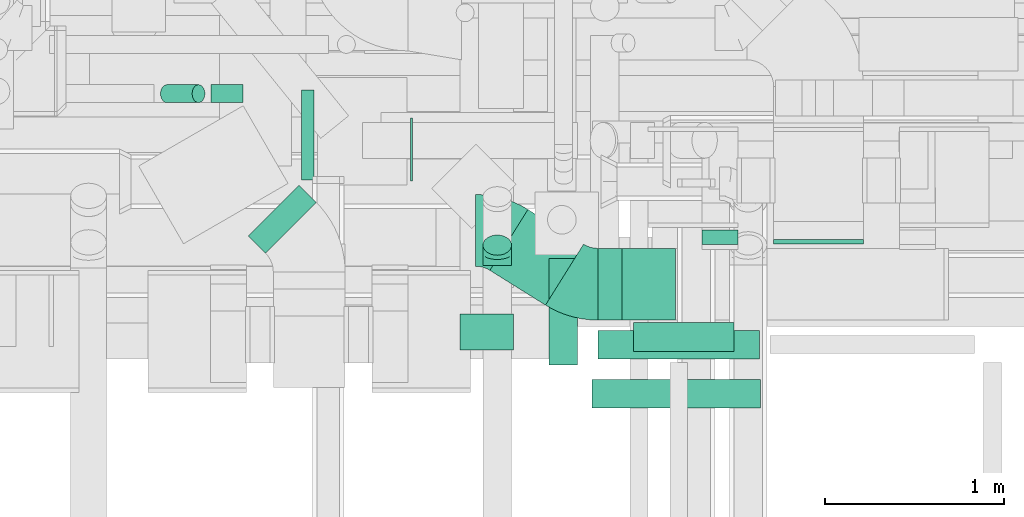
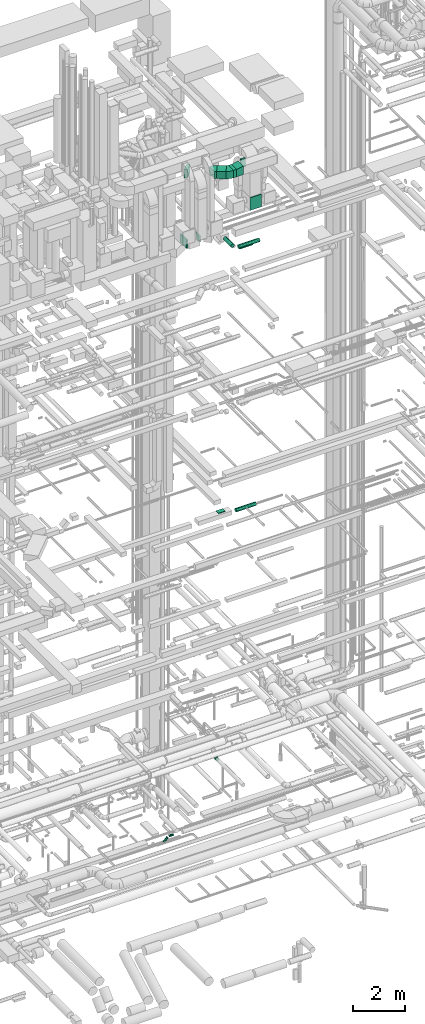
# One storey, part 231 of 337: 13 flow segments, 5 flow fittings.
"""IFC2X3 building model written with IfcOpenShell, lengths in millimetres."""

from ifc_helpers import new_model, entity, si_unit, converted_unit, derived_unit, direction, frame, frame_2d, origin, origin_2d_with_axis, place, context, subcontext, project, spatial, polyline, circle_curve, parameter, trimmed, segment, composite_curve, rectangle, circle, outline, extrude, faceted_brep, source, transform, mapped, material, type_object, type_shapes, element, save


model = new_model("IFC2X3")

# Units and contexts
model_context = context("Model", 3, precision=0.01, world=origin(), true_north=direction((6.12303176911189e-17, 1.0)))
body_context = subcontext(model_context, "Body", "Model", "MODEL_VIEW")
ifc_project = project(units=[si_unit("LENGTHUNIT", "METRE", prefix="MILLI"), si_unit("AREAUNIT", "SQUARE_METRE"), si_unit("VOLUMEUNIT", "CUBIC_METRE"), converted_unit("PLANEANGLEUNIT", "DEGREE", entity("IfcRatioMeasure", 0.0174532925199433), si_unit("PLANEANGLEUNIT", "RADIAN"), dimensions=[0, 0, 0, 0, 0, 0, 0]), si_unit("MASSUNIT", "GRAM", prefix="KILO"), derived_unit("MASSDENSITYUNIT", [(si_unit("MASSUNIT", "GRAM", prefix="KILO"), 1), (si_unit("LENGTHUNIT", "METRE"), -3)]), derived_unit("MOMENTOFINERTIAUNIT", [(si_unit("LENGTHUNIT", "METRE"), 4)]), si_unit("TIMEUNIT", "SECOND"), si_unit("FREQUENCYUNIT", "HERTZ"), si_unit("THERMODYNAMICTEMPERATUREUNIT", "DEGREE_CELSIUS"), derived_unit("THERMALTRANSMITTANCEUNIT", [(si_unit("MASSUNIT", "GRAM", prefix="KILO"), 1), (si_unit("THERMODYNAMICTEMPERATUREUNIT", "KELVIN"), -1), (si_unit("TIMEUNIT", "SECOND"), -3)]), derived_unit("VOLUMETRICFLOWRATEUNIT", [(si_unit("LENGTHUNIT", "METRE"), 3), (si_unit("TIMEUNIT", "SECOND"), -1)]), derived_unit("MASSFLOWRATEUNIT", [(si_unit("MASSUNIT", "GRAM", prefix="KILO"), 1), (si_unit("TIMEUNIT", "SECOND"), -1)]), derived_unit("ROTATIONALFREQUENCYUNIT", [(si_unit("TIMEUNIT", "SECOND"), -1)]), si_unit("ELECTRICCURRENTUNIT", "AMPERE"), si_unit("ELECTRICVOLTAGEUNIT", "VOLT"), si_unit("POWERUNIT", "WATT"), si_unit("FORCEUNIT", "NEWTON", prefix="KILO"), si_unit("ILLUMINANCEUNIT", "LUX"), si_unit("LUMINOUSFLUXUNIT", "LUMEN"), si_unit("LUMINOUSINTENSITYUNIT", "CANDELA"), derived_unit("USERDEFINED", [(si_unit("MASSUNIT", "GRAM", prefix="KILO"), -1), (si_unit("LENGTHUNIT", "METRE"), -2), (si_unit("TIMEUNIT", "SECOND"), 3), (si_unit("LUMINOUSFLUXUNIT", "LUMEN"), 1)]), derived_unit("LINEARVELOCITYUNIT", [(si_unit("LENGTHUNIT", "METRE"), 1), (si_unit("TIMEUNIT", "SECOND"), -1)]), si_unit("PRESSUREUNIT", "PASCAL"), derived_unit("USERDEFINED", [(si_unit("LENGTHUNIT", "METRE"), -2), (si_unit("MASSUNIT", "GRAM", prefix="KILO"), 1), (si_unit("TIMEUNIT", "SECOND"), -2)]), derived_unit("LINEARFORCEUNIT", [(si_unit("MASSUNIT", "GRAM", prefix="KILO"), 1), (si_unit("LENGTHUNIT", "METRE"), 1), (si_unit("TIMEUNIT", "SECOND"), -2), (si_unit("LENGTHUNIT", "METRE"), -1)]), derived_unit("PLANARFORCEUNIT", [(si_unit("MASSUNIT", "GRAM", prefix="KILO"), 1), (si_unit("LENGTHUNIT", "METRE"), 1), (si_unit("TIMEUNIT", "SECOND"), -2), (si_unit("LENGTHUNIT", "METRE"), -2)])], contexts=[model_context])

# Site, building, storey
site_placement = place(None, origin())
site = spatial("IfcSite", under=ifc_project, at=site_placement, CompositionType="ELEMENT")
building_placement = place(site_placement, origin())
building = spatial("IfcBuilding", under=site, at=building_placement, CompositionType="ELEMENT")
storey_placement = place(building_placement, origin())
storey = spatial("IfcBuildingStorey", under=building, at=storey_placement, CompositionType="ELEMENT", Elevation=0.0)

# Flow segments
duct_segment_type_1 = type_object("IfcDuctSegmentType", PredefinedType="NOTDEFINED")
flow_segment_1_placement = place(storey_placement, frame((60120.56, 8169.63, 15070.0)))
element("IfcFlowSegment", 1, at=flow_segment_1_placement, inside=storey, type_object=duct_segment_type_1, context=body_context, shape_type="SweptSolid", body=[
    extrude(rectangle(XDim=300.000000000001, YDim=200.0, at=origin_2d_with_axis()), frame((150.0, 100.0, 0.0)), (0.0, 0.0, 1.0), 30.00000000003),
])
flow_segment_2_placement = place(storey_placement, frame((61470.03, 8756.6, 30600.0)))
element("IfcFlowSegment", 2, at=flow_segment_2_placement, inside=storey, type_object=duct_segment_type_1, context=body_context, shape_type="SweptSolid", body=[
    extrude(rectangle(XDim=82.0000000000203, YDim=199.999999999998, at=origin_2d_with_axis()), frame((100.0, 41.0, 0.0), z_axis=(0.0, 0.0, 1.0), x_axis=(0.0, -1.0, 0.0)), (0.0, 0.0, 1.0), 400.000000000004),
])
flow_segment_3_placement = place(storey_placement, frame((60889.03, 8336.6, 30600.0)))
element("IfcFlowSegment", 3, at=flow_segment_3_placement, inside=storey, type_object=duct_segment_type_1, context=body_context, shape_type="SweptSolid", body=[
    extrude(rectangle(XDim=134.470658806428, YDim=400.0, at=origin_2d_with_axis()), frame((67.24, 200.0, 0.0), z_axis=(0.0, 0.0, 1.0), x_axis=(-1.0, 0.0, 0.0)), (0.0, 0.0, 1.0), 349.999999999998),
])
flow_segment_4_placement = place(storey_placement, frame((60287.7, 8420.18, 30600.0)))
element("IfcFlowSegment", 4, at=flow_segment_4_placement, inside=storey, type_object=duct_segment_type_1, context=body_context, shape_type="SweptSolid", body=[
    extrude(rectangle(XDim=365.402204408748, YDim=399.999999999998, at=origin_2d_with_axis()), frame((260.92, 266.43, 0.0), z_axis=(0.0, 0.0, 1.0), x_axis=(-0.848048096156388, 0.529919264233266, 0.0)), (0.0, 0.0, 1.0), 349.999999999998),
])
flow_segment_5_placement = place(storey_placement, frame((59237.24, 9118.57, 27350.0)))
element("IfcFlowSegment", 5, at=flow_segment_5_placement, inside=storey, type_object=duct_segment_type_1, context=body_context, shape_type="SweptSolid", body=[
    extrude(rectangle(XDim=68.403733792958, YDim=500.0, at=origin_2d_with_axis()), frame((34.2, 250.0, 0.0), z_axis=(0.0, 0.0, 1.0), x_axis=(-1.0, 0.0, 0.0)), (0.0, 0.0, 1.0), 400.000000000004),
])
flow_segment_6_placement = place(storey_placement, frame((59845.64, 9113.12, 27450.0)))
element("IfcFlowSegment", 6, at=flow_segment_6_placement, inside=storey, type_object=duct_segment_type_1, context=body_context, shape_type="SweptSolid", body=[
    extrude(rectangle(XDim=11.4684169262546, YDim=349.999999999999, at=origin_2d_with_axis()), frame((5.73, 175.0, 0.0), z_axis=(0.0, 0.0, 1.0), x_axis=(-1.0, 0.0, 0.0)), (0.0, 0.0, 1.0), 300.000000000001),
])
flow_segment_7_placement = place(storey_placement, frame((58941.48, 8710.41, 31000.0)))
element("IfcFlowSegment", 7, at=flow_segment_7_placement, inside=storey, type_object=duct_segment_type_1, context=body_context, shape_type="SweptSolid", body=[
    extrude(rectangle(XDim=134.314575050798, YDim=399.999999999999, at=origin_2d_with_axis()), frame((188.91, 188.91, 0.0), z_axis=(0.0, 0.0, 1.0), x_axis=(-0.707106781186648, 0.707106781186447, 0.0)), (0.0, 0.0, 1.0), 400.000000000004),
])
duct_segment_type_2 = type_object("IfcDuctSegmentType", PredefinedType="NOTDEFINED")
flow_segment_8_placement = place(storey_placement, frame((58733.86, 9547.39, -601.6)))
element("IfcFlowSegment", 8, at=flow_segment_8_placement, inside=storey, type_object=duct_segment_type_2, context=body_context, shape_type="SweptSolid", body=[
    extrude(circle(Radius=50.0, at=origin_2d_with_axis()), frame((0.0, 51.6, 51.6), z_axis=(1.0, 0.0, 0.0), x_axis=(0.0, -1.0, 0.0)), (0.0, 0.0, 1.0), 178.14982376268),
])
flow_segment_9_placement = place(storey_placement, frame((58449.78, 9547.39, -792.66)))
element("IfcFlowSegment", 9, at=flow_segment_9_placement, inside=storey, type_object=duct_segment_type_2, context=body_context, shape_type="SweptSolid", body=[
    extrude(circle(Radius=50.0, at=origin_2d_with_axis()), frame((36.95, 51.6, 36.95), z_axis=(0.707106781186546, 0.0, 0.707106781186549), x_axis=(0.0, 1.0, 0.0)), (0.0, 0.0, 1.0), 249.497474683054),
])
flow_segment_10_placement = place(storey_placement, frame((60890.56, 8118.04, 14868.4)))
element("IfcFlowSegment", 10, at=flow_segment_10_placement, inside=storey, type_object=duct_segment_type_2, context=body_context, shape_type="SweptSolid", body=[
    extrude(circle(Radius=80.0, at=origin_2d_with_axis()), frame((0.0, 81.6, 81.6), z_axis=(1.0, 0.0, 0.0), x_axis=(0.0, 1.0, 0.0)), (0.0, 0.0, 1.0), 900.000000000003),
])
flow_segment_11_placement = place(storey_placement, frame((60856.21, 7844.07, 27518.4)))
element("IfcFlowSegment", 11, at=flow_segment_11_placement, inside=storey, type_object=duct_segment_type_2, context=body_context, shape_type="SweptSolid", body=[
    extrude(circle(Radius=80.0, at=origin_2d_with_axis()), frame((0.0, 81.6, 81.6), z_axis=(1.0, 0.0, 0.0), x_axis=(0.0, 1.0, 0.0)), (0.0, 0.0, 1.0), 939.375000000018),
])
flow_segment_12_placement = place(storey_placement, frame((60614.62, 8085.66, 27518.4)))
element("IfcFlowSegment", 12, at=flow_segment_12_placement, inside=storey, type_object=duct_segment_type_2, context=body_context, shape_type="SweptSolid", body=[
    extrude(circle(Radius=80.0, at=origin_2d_with_axis()), frame((81.6, 0.0, 81.6), z_axis=(0.0, 1.0, 0.0), x_axis=(1.0, 0.0, 0.0)), (0.0, 0.0, 1.0), 594.360142446069),
])
flow_segment_13_placement = place(storey_placement, frame((61088.45, 8160.81, 27218.4)))
element("IfcFlowSegment", 13, at=flow_segment_13_placement, inside=storey, type_object=duct_segment_type_2, context=body_context, shape_type="SweptSolid", body=[
    extrude(circle(Radius=80.0, at=origin_2d_with_axis()), frame((0.0, 81.6, 81.6), z_axis=(1.0, 0.0, 0.0), x_axis=(0.0, -1.0, 0.0)), (0.0, 0.0, 1.0), 559.999999999959),
])

# Flow fittings
ifc_material = material()
duct_fitting_type_1 = type_object("IfcDuctFittingType", PredefinedType="NOTDEFINED", material=ifc_material)
shared_shape_1 = source(origin(), body_context, "Body", "SweptSolid", [
    extrude(rectangle(XDim=24.9999999999999, YDim=500.0, at=origin_2d_with_axis()), frame((12.5, 0.0, -300.0)), (0.0, 0.0, 1.0), 600.0),
])
type_shapes(duct_fitting_type_1, [shared_shape_1])
flow_fitting_1_placement = place(storey_placement, frame((62120.03, 8786.6, 28750.0), z_axis=(0.0, 0.0, 1.0), x_axis=(0.0, -1.0, 0.0)))
element("IfcFlowFitting", 14, at=flow_fitting_1_placement, inside=storey, type_object=duct_fitting_type_1, material=ifc_material, context=body_context, shape_type="MappedRepresentation", body=[
    mapped(shared_shape_1, transform((0.0, 0.0, 0.0), scale=1.0)),
])
duct_fitting_type_2 = type_object("IfcDuctFittingType", PredefinedType="NOTDEFINED", material=ifc_material)
shared_shape_2 = source(origin(), body_context, "Body", "SweptSolid", [
    extrude(outline(polyline([(-121.24, -184.95), (182.89, -184.95), (117.13, 209.61), (-178.78, 160.29), (-121.24, -184.95)])), frame((150.0, -200.0, 12.5), z_axis=(0.0, 1.0, 0.0), x_axis=(0.986393923832155, 0.0, 0.164398987305288)), (0.0, 0.0, 1.0), 400.0),
])
type_shapes(duct_fitting_type_2, [shared_shape_2])
flow_fitting_2_placement = place(storey_placement, frame((61023.5, 8536.6, 30775.0)))
element("IfcFlowFitting", 15, at=flow_fitting_2_placement, inside=storey, type_object=duct_fitting_type_2, material=ifc_material, context=body_context, shape_type="MappedRepresentation", body=[
    mapped(shared_shape_2, transform((0.0, 0.0, 0.0), scale=1.0)),
])
duct_fitting_type_3 = type_object("IfcDuctFittingType", PredefinedType="NOTDEFINED", material=ifc_material)
shared_shape_3 = source(origin(), body_context, "Body", "Brep", [
    faceted_brep([(-66.27, 0.0, -80.0), (-66.27, -20.71, -77.27), (-66.27, -40.0, -69.28), (-66.27, -56.57, -56.57), (-66.27, -69.28, -40.0), (-66.27, -77.27, -20.71), (-66.27, -80.0, 0.0), (-66.27, -77.27, 20.71), (-66.27, -69.28, 40.0), (-66.27, -56.57, 56.57), (-66.27, -40.0, 69.28), (-66.27, -20.71, 77.27), (-66.27, 0.0, 80.0), (-66.27, 20.71, 77.27), (-66.27, 40.0, 69.28), (-66.27, 56.57, 56.57), (-66.27, 69.28, 40.0), (-66.27, 77.27, 20.71), (-66.27, 80.0, 0.0), (-66.27, 77.27, -20.71), (-66.27, 69.28, -40.0), (-66.27, 56.57, -56.57), (-66.27, 40.0, -69.28), (-66.27, 20.71, -77.27), (-8.58, 20.71, 77.27), (-16.57, 40.0, 69.28), (0.0, 0.0, 80.0), (-23.43, 56.57, 56.57), (-28.7, 69.28, 40.0), (-32.01, 77.27, 20.71), (-33.14, 80.0, 0.0), (-32.01, 77.27, -20.71), (-28.7, 69.28, -40.0), (-23.43, 56.57, -56.57), (-8.58, 20.71, -77.27), (0.0, 0.0, -80.0), (-16.57, 40.0, -69.28), (8.58, -20.71, -77.27), (16.57, -40.0, -69.28), (23.43, -56.57, -56.57), (28.7, -69.28, -40.0), (32.01, -77.27, -20.71), (33.14, -80.0, 0.0), (32.01, -77.27, 20.71), (28.7, -69.28, 40.0), (23.43, -56.57, 56.57), (16.57, -40.0, 69.28), (8.58, -20.71, 77.27), (46.86, 46.86, 80.0), (32.22, 61.5, 77.27), (18.58, 75.15, 69.28), (6.86, 86.86, 56.57), (-2.13, 95.85, 40.0), (-7.78, 101.5, 20.71), (-9.71, 103.43, 0.0), (-7.78, 101.5, -20.71), (-2.13, 95.85, -40.0), (6.86, 86.86, -56.57), (18.58, 75.15, -69.28), (32.22, 61.5, -77.27), (46.86, 46.86, -80.0), (61.5, 32.22, -77.27), (75.15, 18.58, -69.28), (86.86, 6.86, -56.57), (95.85, -2.13, -40.0), (101.5, -7.78, -20.71), (103.43, -9.71, 0.0), (101.5, -7.78, 20.71), (95.85, -2.13, 40.0), (86.86, 6.86, 56.57), (75.15, 18.58, 69.28), (61.5, 32.22, 77.27)], [[[0, 1, 2, 3, 4, 5, 6, 7, 8, 9, 10, 11, 12, 13, 14, 15, 16, 17, 18, 19, 20, 21, 22, 23]], [[24, 25, 14, 13]], [[26, 24, 13, 12]], [[14, 25, 27, 15]], [[28, 29, 17, 16]], [[28, 16, 15, 27]], [[30, 18, 17, 29]], [[31, 32, 20, 19]], [[30, 31, 19, 18]], [[32, 33, 21, 20]], [[34, 35, 0, 23]], [[36, 34, 23, 22]], [[33, 36, 22, 21]], [[1, 0, 35, 37]], [[2, 1, 37, 38]], [[38, 39, 3, 2]], [[5, 4, 40, 41]], [[6, 5, 41, 42]], [[39, 40, 4, 3]], [[6, 42, 43, 7]], [[7, 43, 44, 8]], [[8, 44, 45, 9]], [[9, 45, 46, 10]], [[10, 46, 47, 11]], [[26, 12, 11, 47]], [[24, 26, 48, 49]], [[25, 24, 49, 50]], [[27, 25, 50, 51]], [[29, 28, 52, 53]], [[30, 29, 53, 54]], [[51, 52, 28, 27]], [[30, 54, 55, 31]], [[31, 55, 56, 32]], [[57, 33, 32, 56]], [[36, 58, 59, 34]], [[34, 59, 60, 35]], [[58, 36, 33, 57]], [[35, 60, 61, 37]], [[37, 61, 62, 38]], [[63, 39, 38, 62]], [[40, 64, 65, 41]], [[41, 65, 66, 42]], [[64, 40, 39, 63]], [[43, 42, 66, 67]], [[44, 43, 67, 68]], [[68, 69, 45, 44]], [[47, 46, 70, 71]], [[26, 47, 71, 48]], [[69, 70, 46, 45]], [[59, 58, 57, 56, 55, 54, 53, 52, 51, 50, 49, 48, 71, 70, 69, 68, 67, 66, 65, 64, 63, 62, 61, 60]]]),
])
type_shapes(duct_fitting_type_3, [shared_shape_3])
flow_fitting_3_placement = place(storey_placement, frame((60328.78, 8707.6, 3100.0), z_axis=(1.0, -1.94584319794178e-08, 1.9458431979417e-08), x_axis=(1.94584319794178e-08, 1.0, 0.0)))
element("IfcFlowFitting", 16, at=flow_fitting_3_placement, inside=storey, type_object=duct_fitting_type_3, material=ifc_material, context=body_context, shape_type="MappedRepresentation", body=[
    mapped(shared_shape_3, transform((0.0, 0.0, 0.0), scale=1.0)),
])
duct_fitting_type_4 = type_object("IfcDuctFittingType", PredefinedType="NOTDEFINED", material=ifc_material)
shared_shape_4 = source(origin(), body_context, "Body", "SweptSolid", [
    extrude(outline(composite_curve([segment(polyline([(-226.59, -92.74), (173.41, -92.74)]), True, "CONTINUOUS"), segment(trimmed(circle_curve(frame_2d((323.41, -92.74), x_axis=(-0.848048096156425, 0.529919264233205)), 150.0), [parameter(0.0)], [parameter(32.0)], True, "PARAMETER"), False, "CONTINUOUS"), segment(polyline([(196.2, -13.25), (-143.02, 198.72)]), True, "CONTINUOUS"), segment(trimmed(circle_curve(frame_2d((323.41, -92.74), x_axis=(-0.848048096156425, 0.529919264233205)), 550.0), [parameter(0.0)], [parameter(32.0)], True, "PARAMETER"), True, "CONTINUOUS")], self_intersect=False)), frame((-7.63, 26.59, -175.0), z_axis=(0.0, 0.0, 1.0), x_axis=(-0.529919264233205, 0.848048096156426, 0.0)), (0.0, 0.0, 1.0), 350.0),
])
type_shapes(duct_fitting_type_4, [shared_shape_4])
for number, where, z_axis, x_axis in (
    (17, (60788.67, 8536.6, 30775.0), (0.0, 0.0, 1.0), (0.848048096156426, -0.529919264233205, 0.0)),
    (18, (60308.57, 8836.6, 30775.0), (0.0, 0.0, 1.0), (-0.84804809615641, 0.52991926423323, 0.0)),
):
    element("IfcFlowFitting", number, at=place(storey_placement, frame(where, z_axis=z_axis, x_axis=x_axis)), inside=storey, type_object=duct_fitting_type_4, material=ifc_material, context=body_context, shape_type="MappedRepresentation", body=[
        mapped(shared_shape_4, transform((0.0, 0.0, 0.0), scale=1.0)),
    ])

save(model, "model.ifc")
